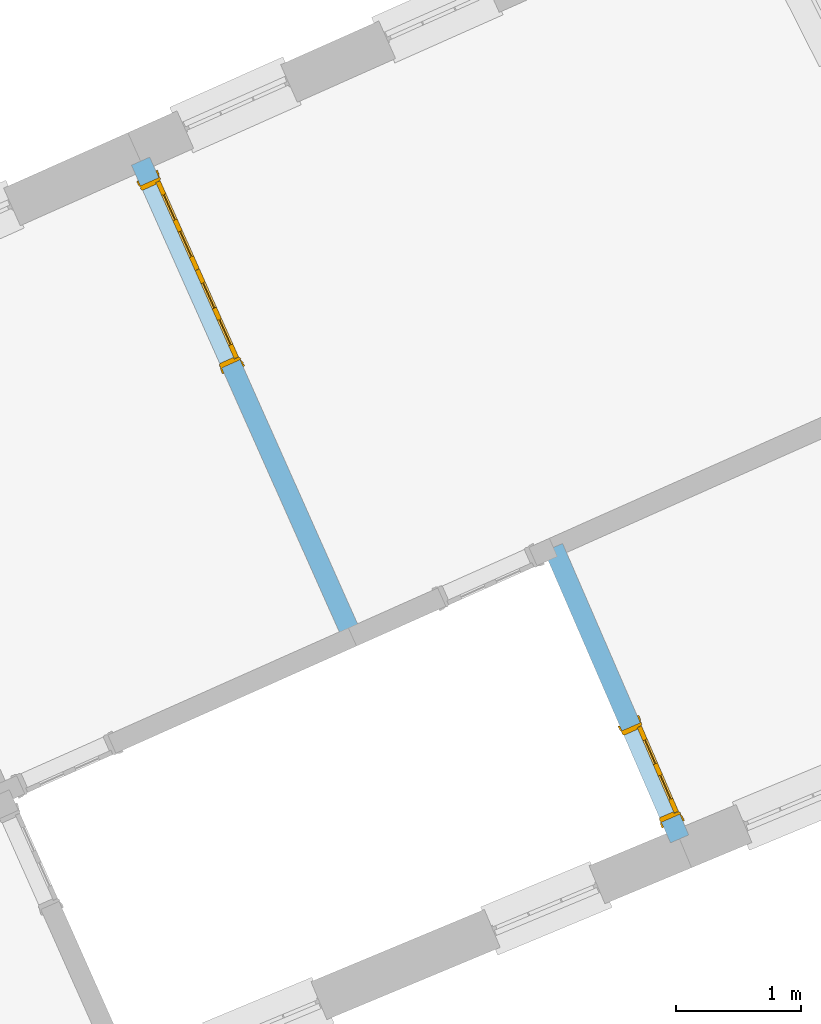
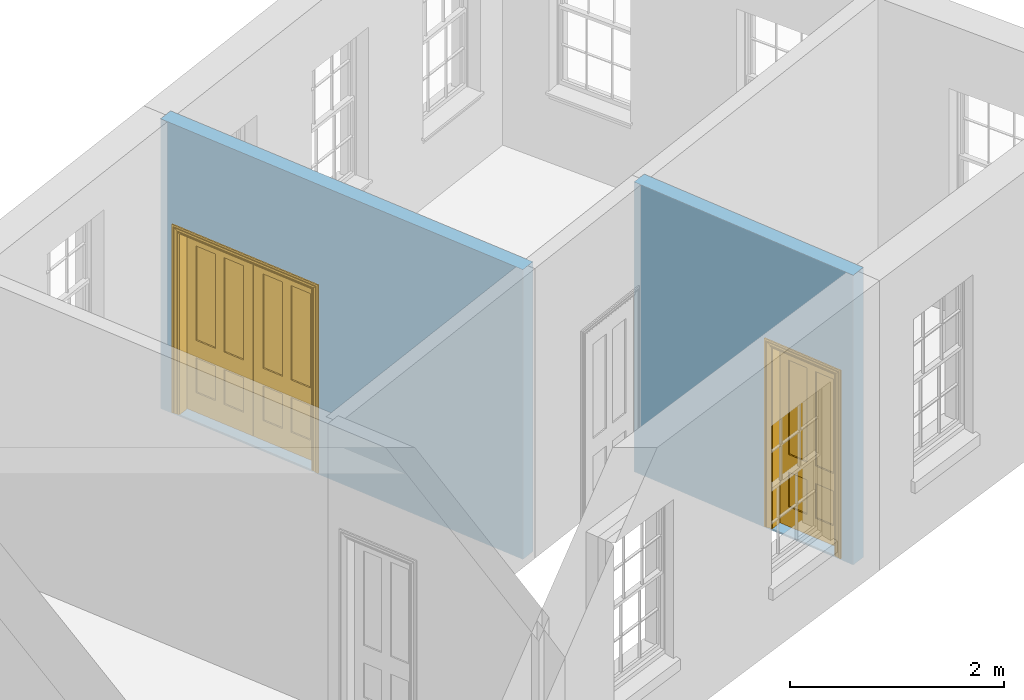
# One storey, part 5 of 8: 2 doors, 2 openings, plus 2 elements that do not belong to this part.
"""IFC2X3 building model written with IfcOpenShell, lengths in metres."""

from ifc_helpers import new_model, si_unit, frame, origin, place, context, subcontext, project, spatial, polyline, outline, extrude, faceted_brep, material, layer, layer_set, layer_usage, element, fill, save


model = new_model("IFC2X3")

# Units and contexts
model_context = context("Model", 3, world=origin())
body_context = subcontext(model_context, "Body", "Model", "MODEL_VIEW")
ifc_project = project(units=[si_unit("PLANEANGLEUNIT", "RADIAN"), si_unit("MASSUNIT", "GRAM", prefix="KILO"), si_unit("FORCEUNIT", "NEWTON", prefix="KILO"), si_unit("LENGTHUNIT", "METRE")], contexts=[model_context])

# Site, building, storey
site_placement = place(None, origin())
site = spatial("IfcSite", under=ifc_project, at=site_placement, CompositionType="ELEMENT")
building_placement = place(None, origin())
building = spatial("IfcBuilding", under=site, at=building_placement, Name="Building plot-1", CompositionType="ELEMENT")
storey_placement = place(None, frame((0.0, 0.0, 5.15)))
storey = spatial("IfcBuildingStorey", under=building, at=storey_placement, Name="Floor 1", CompositionType="ELEMENT", Elevation=5.15)

# Wall, opening, door
ifc_material = material(Name="Masonry")
ifc_layer = layer(ifc_material, 0.16, ventilated=False)
ifc_layer_set = layer_set([ifc_layer], Name="My Wall")
ifc_layer_usage = layer_usage(ifc_layer_set, "AXIS2", "NEGATIVE", 0.08)
wall_1_placement = place(storey_placement, origin())
wall_1 = element("IfcWallStandardCase", 1, at=wall_1_placement, inside=storey, material=ifc_layer_usage, Name="interior", context=body_context, shape_type="SweptSolid", body=[
    extrude(outline(polyline([(24.4842191435826, 48.6456324048901), (24.3380587544284, 48.5805390823271), (26.0373868902466, 44.7648717933949), (26.1835472794008, 44.8299651159579), (24.4842191435826, 48.6456324048901)])), origin(), (0.0, 0.0, 1.0), 3.3),
])
opening_1_placement = place(storey_placement, frame((0.0, 0.0, 0.0199999999999996)))
opening_1 = element("IfcOpeningElement", 2, at=opening_1_placement, cuts=wall_1, Name="Opening", ObjectType="Opening", context=body_context, shape_type="SweptSolid", body=[
    extrude(outline(polyline([(24.4112887423119, 48.4161086445286), (25.0622219679426, 46.9545047529869), (25.2083823570968, 47.0195980755499), (24.557449131466, 48.4812019670917), (24.4112887423119, 48.4161086445286)])), origin(), (0.0, 0.0, 1.0), 2.1),
])
door_1_placement = place(storey_placement, frame((24.484368936889, 48.4486553058102, 0.0199999999999996), z_axis=(0.0, 0.0, 1.0), x_axis=(0.650933225630723, -1.46160389154175, 0.0)))
door_1 = element("IfcDoor", 3, at=door_1_placement, inside=storey, Name="kitchen living inside door", OverallHeight=2.1, OverallWidth=1.6, context=body_context, shape_type="Brep", held_by="IfcProductRepresentation", body=[
    faceted_brep([(0.14, 0.057, 1.895), (0.14, 0.057, 0.82), (0.363, 0.057, 0.82), (0.363, 0.057, 1.895), (0.14, 0.042, 1.895), (0.14, 0.042, 0.82), (0.363, 0.042, 0.82), (0.363, 0.042, 1.895), (0.027, 0.042, 1.895), (0.027, 0.042, 0.82), (0.363, 0.042, 0.62), (0.14, 0.042, 0.62), (0.463, 0.042, 0.82), (0.463, 0.042, 1.895), (0.363, 0.042, 2.073), (0.14, 0.042, 2.073), (0.027, 0.042, 2.073), (0.027, 0.08, 1.895), (0.027, 0.08, 0.82), (0.027, 0.042, 0.62), (0.463, 0.042, 0.62), (0.14, 0.057, 0.62), (0.363, 0.057, 0.62), (0.463, 0.057, 0.82), (0.463, 0.057, 1.895), (0.463, 0.042, 2.073), (0.14, 0.08, 2.073), (0.363, 0.08, 2.073), (0.027, 0.08, 2.073), (0.14, 0.08, 1.895), (0.14, 0.08, 0.82), (0.027, 0.08, 0.62), (0.027, 0.042, 0.225), (0.14, 0.042, 0.225), (0.363, 0.042, 0.225), (0.463, 0.042, 0.225), (0.686, 0.042, 0.62), (0.686, 0.042, 0.82), (0.14, 0.057, 0.225), (0.363, 0.057, 0.225), (0.686, 0.057, 0.82), (0.686, 0.057, 1.895), (0.686, 0.042, 1.895), (0.686, 0.042, 2.073), (0.463, 0.08, 2.073), (0.363, 0.08, 1.895), (0.14, 0.065, 1.895), (0.14, 0.065, 0.82), (0.14, 0.08, 0.62), (0.027, 0.08, 0.225), (0.027, 0.042, 0.0), (0.14, 0.042, 0.0), (0.363, 0.042, 0.0), (0.463, 0.042, 0.0), (0.463, 0.057, 0.225), (0.463, 0.057, 0.62), (0.686, 0.057, 0.62), (0.799, 0.042, 0.62), (0.799, 0.042, 0.82), (0.799, 0.042, 1.895), (0.799, 0.042, 2.073), (0.686, 0.08, 2.073), (0.463, 0.08, 1.895), (0.363, 0.065, 1.895), (0.363, 0.065, 0.82), (0.363, 0.08, 0.82), (0.363, 0.08, 0.62), (0.14, 0.08, 0.225), (0.027, 0.08, 0.0), (0.14, 0.08, 0.0), (0.363, 0.08, 0.0), (0.463, 0.08, 0.0), (0.686, 0.042, 0.0), (0.686, 0.042, 0.225), (0.686, 0.057, 0.225), (0.799, 0.042, 0.225), (0.799, 0.08, 0.62), (0.799, 0.08, 0.82), (0.799, 0.08, 1.895), (0.799, 0.08, 2.073), (0.686, 0.08, 1.895), (0.463, 0.08, 0.82), (0.463, 0.08, 0.62), (0.363, 0.065, 0.62), (0.14, 0.065, 0.62), (0.14, 0.065, 0.225), (0.363, 0.08, 0.225), (0.463, 0.08, 0.225), (0.686, 0.08, 0.0), (0.799, 0.042, 0.0), (0.799, 0.08, 0.225), (0.686, 0.08, 0.62), (0.686, 0.08, 0.82), (0.686, 0.065, 1.895), (0.463, 0.065, 1.895), (0.463, 0.065, 0.82), (0.363, 0.065, 0.225), (0.686, 0.08, 0.225), (0.799, 0.08, 0.0), (0.686, 0.065, 0.82), (0.463, 0.065, 0.62), (0.463, 0.065, 0.225), (0.686, 0.065, 0.62), (0.686, 0.065, 0.225), (1.46, 0.08, 1.895), (1.237, 0.08, 1.895), (1.237, 0.08, 2.073), (1.46, 0.08, 2.073), (1.46, 0.065, 1.895), (1.237, 0.065, 1.895), (1.137, 0.08, 1.895), (1.137, 0.08, 2.073), (1.237, 0.042, 2.073), (1.46, 0.042, 2.073), (1.573, 0.08, 1.895), (1.573, 0.08, 2.073), (1.46, 0.08, 0.82), (1.46, 0.065, 0.82), (1.237, 0.065, 0.82), (1.237, 0.08, 0.82), (1.137, 0.08, 0.82), (0.914, 0.08, 2.073), (0.914, 0.08, 1.895), (1.137, 0.042, 2.073), (1.237, 0.042, 1.895), (1.46, 0.042, 1.895), (1.573, 0.042, 2.073), (1.573, 0.08, 0.82), (1.573, 0.042, 1.895), (1.237, 0.08, 0.62), (1.137, 0.08, 0.62), (1.137, 0.065, 0.82), (1.137, 0.065, 1.895), (0.914, 0.042, 2.073), (0.914, 0.065, 1.895), (0.801, 0.08, 2.073), (0.801, 0.08, 1.895), (1.137, 0.042, 1.895), (1.237, 0.057, 1.895), (1.46, 0.057, 1.895), (1.573, 0.042, 0.82), (1.573, 0.08, 0.62), (1.46, 0.08, 0.62), (1.237, 0.08, 0.225), (1.137, 0.08, 0.225), (0.914, 0.08, 0.82), (0.914, 0.08, 0.62), (0.914, 0.065, 0.82), (0.801, 0.042, 2.073), (0.914, 0.042, 1.895), (0.801, 0.08, 0.82), (0.801, 0.042, 1.895), (1.137, 0.042, 0.82), (1.237, 0.042, 0.82), (1.237, 0.057, 0.82), (1.46, 0.057, 0.82), (1.46, 0.042, 0.82), (1.573, 0.042, 0.62), (1.573, 0.08, 0.225), (1.46, 0.08, 0.225), (1.46, 0.065, 0.62), (1.237, 0.065, 0.62), (1.237, 0.08, 0.0), (1.137, 0.08, 0.0), (1.137, 0.065, 0.225), (1.137, 0.065, 0.62), (1.237, 0.065, 0.225), (0.914, 0.065, 0.62), (0.801, 0.08, 0.62), (0.914, 0.057, 1.895), (1.137, 0.057, 1.895), (0.801, 0.042, 0.82), (1.137, 0.042, 0.62), (1.237, 0.042, 0.62), (1.137, 0.057, 0.82), (1.46, 0.042, 0.62), (1.573, 0.042, 0.225), (1.573, 0.08, 0.0), (1.46, 0.08, 0.0), (1.46, 0.065, 0.225), (1.237, 0.042, 0.0), (1.137, 0.042, 0.0), (0.914, 0.08, 0.225), (0.914, 0.08, 0.0), (0.914, 0.065, 0.225), (0.801, 0.08, 0.225), (0.801, 0.042, 0.62), (0.914, 0.042, 0.82), (0.914, 0.057, 0.82), (1.137, 0.042, 0.225), (1.237, 0.042, 0.225), (0.914, 0.042, 0.62), (1.46, 0.042, 0.225), (1.573, 0.042, 0.0), (1.46, 0.042, 0.0), (0.914, 0.042, 0.0), (0.801, 0.08, 0.0), (0.801, 0.042, 0.225), (1.237, 0.057, 0.225), (1.237, 0.057, 0.62), (1.137, 0.057, 0.62), (1.137, 0.057, 0.225), (1.46, 0.057, 0.62), (0.914, 0.057, 0.62), (1.46, 0.057, 0.225), (0.914, 0.042, 0.225), (0.801, 0.042, 0.0), (0.914, 0.057, 0.225), (0.02, 0.085, 0.0), (0.005, 0.09, 0.0), (0.005, 0.09, 2.095), (0.02, 0.085, 2.08), (0.02, 0.08, 0.0), (0.0, 0.085, 0.0), (0.0, 0.085, 2.1), (1.595, 0.09, 2.095), (1.58, 0.085, 2.08), (0.02, 0.08, 2.08), (0.0, 0.08, 0.0), (-0.032, 0.095, 0.0), (-0.032, 0.095, 2.132), (1.6, 0.085, 2.1), (1.595, 0.09, 0.0), (1.58, 0.085, 0.0), (1.58, 0.08, 2.08), (0.025, 0.08, 0.0), (0.025, 0.08, 2.075), (-0.04, 0.09, 0.0), (0.025, 0.04, 0.0), (0.0, -0.08, 0.0), (-0.04, 0.09, 2.14), (1.632, 0.095, 2.132), (1.6, 0.085, 0.0), (1.58, 0.08, 0.0), (1.575, 0.08, 2.075), (0.025, 0.04, 2.075), (-0.06, 0.08, 0.0), (0.035, -0.08, 0.0), (0.0, -0.08, 2.1), (0.0, 0.08, 2.1), (-0.04, 0.095, 0.0), (-0.04, 0.095, 2.14), (1.64, 0.09, 2.14), (1.632, 0.095, 0.0), (1.6, 0.08, 0.0), (1.575, 0.08, 0.0), (1.575, 0.04, 2.075), (0.04, 0.04, 0.0), (0.04, 0.04, 2.06), (-0.06, 0.095, 0.0), (-0.06, 0.08, 2.16), (0.015, -0.085, 0.0), (0.04, -0.08, 0.0), (-0.045, -0.08, 2.145), (-0.045, -0.08, 0.0), (1.6, -0.08, 2.1), (1.6, 0.08, 2.1), (-0.06, 0.095, 2.16), (1.64, 0.095, 2.14), (1.64, 0.09, 0.0), (1.6, -0.08, 0.0), (1.575, 0.04, 0.0), (1.56, 0.04, 2.06), (0.04, -0.08, 2.06), (1.66, 0.08, 2.16), (-0.017, -0.095, 0.0), (-0.025, -0.09, 0.0), (0.02, -0.09, 0.0), (0.035, -0.085, 0.0), (0.035, -0.08, 2.065), (1.645, -0.08, 2.145), (-0.045, -0.095, 2.145), (-0.045, -0.095, 0.0), (1.66, 0.095, 2.16), (1.64, 0.095, 0.0), (1.66, 0.08, 0.0), (1.565, -0.08, 0.0), (1.56, 0.04, 0.0), (1.56, -0.08, 2.06), (-0.017, -0.095, 2.117), (-0.025, -0.09, 2.125), (0.015, -0.085, 2.085), (0.02, -0.09, 2.08), (0.035, -0.085, 2.065), (1.565, -0.08, 2.065), (1.645, -0.08, 0.0), (1.645, -0.095, 2.145), (-0.025, -0.095, 0.0), (1.66, 0.095, 0.0), (1.585, -0.085, 0.0), (1.56, -0.08, 0.0), (1.617, -0.095, 2.117), (1.625, -0.09, 2.125), (-0.025, -0.095, 2.125), (1.585, -0.085, 2.085), (1.58, -0.09, 2.08), (1.565, -0.085, 2.065), (1.625, -0.09, 0.0), (1.645, -0.095, 0.0), (1.625, -0.095, 2.125), (1.617, -0.095, 0.0), (1.565, -0.085, 0.0), (1.58, -0.09, 0.0), (1.625, -0.095, 0.0)], [[[0, 1, 2, 3]], [[1, 0, 4, 5]], [[2, 1, 5, 6]], [[6, 7, 3, 2]], [[7, 4, 0, 3]], [[4, 8, 9, 5]], [[10, 6, 5, 11]], [[6, 12, 13, 7]], [[14, 15, 4, 7]], [[15, 16, 8, 4]], [[9, 8, 17, 18]], [[5, 9, 19, 11]], [[10, 20, 12, 6]], [[10, 11, 21, 22]], [[13, 12, 23, 24]], [[7, 13, 25, 14]], [[26, 15, 14, 27]], [[28, 16, 15, 26]], [[8, 16, 28, 17]], [[17, 29, 30, 18]], [[18, 31, 19, 9]], [[11, 19, 32, 33]], [[34, 35, 20, 10]], [[20, 36, 37, 12]], [[11, 33, 38, 21]], [[39, 22, 21, 38]], [[34, 10, 22, 39]], [[12, 37, 40, 23]], [[24, 23, 40, 41]], [[42, 13, 24, 41]], [[13, 42, 43, 25]], [[14, 25, 44, 27]], [[26, 27, 45, 29]], [[28, 26, 29, 17]], [[30, 29, 46, 47]], [[18, 30, 48, 31]], [[31, 49, 32, 19]], [[33, 32, 50, 51]], [[52, 53, 35, 34]], [[20, 35, 54, 55]], [[36, 20, 55, 56]], [[36, 57, 58, 37]], [[33, 34, 39, 38]], [[37, 42, 41, 40]], [[42, 59, 60, 43]], [[44, 25, 43, 61]], [[62, 45, 27, 44]], [[29, 45, 63, 46]], [[46, 63, 64, 47]], [[65, 30, 47, 64]], [[30, 65, 66, 48]], [[31, 48, 67, 49]], [[68, 50, 32, 49]], [[68, 69, 51, 50]], [[34, 33, 51, 52]], [[53, 52, 70, 71]], [[53, 72, 73, 35]], [[35, 73, 74, 54]], [[55, 54, 74, 56]], [[73, 36, 56, 74]], [[73, 75, 57, 36]], [[57, 76, 77, 58]], [[37, 58, 59, 42]], [[78, 79, 60, 59]], [[60, 79, 61, 43]], [[80, 62, 44, 61]], [[81, 65, 45, 62]], [[45, 65, 64, 63]], [[82, 66, 65, 81]], [[48, 66, 83, 84]], [[67, 48, 84, 85]], [[49, 67, 69, 68]], [[52, 51, 69, 70]], [[71, 70, 86, 87]], [[72, 53, 71, 88]], [[72, 89, 75, 73]], [[75, 90, 76, 57]], [[76, 91, 92, 77]], [[78, 59, 58, 77]], [[78, 80, 61, 79]], [[62, 80, 93, 94]], [[81, 62, 94, 95]], [[87, 86, 66, 82]], [[91, 82, 81, 92]], [[66, 86, 96, 83]], [[84, 83, 96, 85]], [[86, 67, 85, 96]], [[67, 86, 70, 69]], [[88, 71, 87, 97]], [[89, 72, 88, 98]], [[89, 98, 90, 75]], [[90, 97, 91, 76]], [[80, 78, 77, 92]], [[80, 92, 99, 93]], [[99, 95, 94, 93]], [[92, 81, 95, 99]], [[87, 82, 100, 101]], [[82, 91, 102, 100]], [[97, 87, 101, 103]], [[98, 88, 97, 90]], [[91, 97, 103, 102]], [[103, 101, 100, 102]], [[104, 105, 106, 107]], [[105, 104, 108, 109]], [[105, 110, 111, 106]], [[106, 112, 113, 107]], [[114, 104, 107, 115]], [[104, 116, 117, 108]], [[117, 118, 109, 108]], [[119, 105, 109, 118]], [[119, 120, 110, 105]], [[121, 111, 110, 122]], [[123, 112, 106, 111]], [[124, 125, 113, 112]], [[126, 115, 107, 113]], [[104, 114, 127, 116]], [[114, 115, 126, 128]], [[116, 119, 118, 117]], [[129, 130, 120, 119]], [[110, 120, 131, 132]], [[121, 133, 123, 111]], [[122, 110, 132, 134]], [[135, 121, 122, 136]], [[137, 124, 112, 123]], [[125, 124, 138, 139]], [[125, 128, 126, 113]], [[114, 128, 140, 127]], [[141, 142, 116, 127]], [[142, 129, 119, 116]], [[143, 144, 130, 129]], [[145, 120, 130, 146]], [[120, 145, 147, 131]], [[134, 132, 131, 147]], [[135, 148, 133, 121]], [[123, 133, 149, 137]], [[145, 122, 134, 147]], [[136, 122, 145, 150]], [[151, 148, 135, 136]], [[152, 153, 124, 137]], [[124, 153, 154, 138]], [[138, 154, 155, 139]], [[156, 125, 139, 155]], [[156, 140, 128, 125]], [[157, 141, 127, 140]], [[158, 159, 142, 141]], [[129, 142, 160, 161]], [[162, 163, 144, 143]], [[130, 144, 164, 165]], [[143, 129, 161, 166]], [[146, 130, 165, 167]], [[150, 145, 146, 168]], [[133, 148, 151, 149]], [[137, 149, 169, 170]], [[171, 151, 136, 150]], [[172, 173, 153, 152]], [[152, 137, 170, 174]], [[153, 156, 155, 154]], [[175, 157, 140, 156]], [[176, 158, 141, 157]], [[177, 178, 159, 158]], [[142, 159, 179, 160]], [[179, 166, 161, 160]], [[180, 181, 163, 162]], [[182, 144, 163, 183]], [[178, 162, 143, 159]], [[144, 182, 184, 164]], [[167, 165, 164, 184]], [[159, 143, 166, 179]], [[182, 146, 167, 184]], [[168, 146, 182, 185]], [[150, 168, 186, 171]], [[149, 151, 171, 187]], [[149, 187, 188, 169]], [[169, 188, 174, 170]], [[189, 190, 173, 172]], [[173, 175, 156, 153]], [[172, 152, 187, 191]], [[187, 152, 174, 188]], [[192, 176, 157, 175]], [[193, 177, 158, 176]], [[193, 194, 178, 177]], [[181, 180, 190, 189]], [[181, 195, 183, 163]], [[194, 180, 162, 178]], [[185, 182, 183, 196]], [[168, 185, 197, 186]], [[187, 171, 186, 191]], [[173, 190, 198, 199]], [[189, 172, 200, 201]], [[175, 173, 199, 202]], [[172, 191, 203, 200]], [[194, 193, 176, 192]], [[192, 175, 202, 204]], [[180, 194, 192, 190]], [[189, 205, 195, 181]], [[196, 183, 195, 206]], [[196, 206, 197, 185]], [[191, 186, 197, 205]], [[190, 192, 204, 198]], [[199, 198, 204, 202]], [[201, 200, 203, 207]], [[205, 189, 201, 207]], [[191, 205, 207, 203]], [[205, 197, 206, 195]], [[208, 209, 210, 211]], [[208, 212, 213, 209]], [[209, 213, 214, 210]], [[211, 210, 215, 216]], [[211, 217, 212, 208]], [[218, 213, 212]], [[213, 219, 220, 214]], [[210, 214, 221, 215]], [[216, 215, 222, 223]], [[217, 211, 216, 224]], [[225, 212, 217, 226]], [[219, 213, 218, 227]], [[218, 212, 228, 229]], [[219, 227, 230, 220]], [[214, 220, 231, 221]], [[215, 221, 232, 222]], [[222, 232, 233, 223]], [[224, 216, 223, 233]], [[226, 217, 224, 234]], [[225, 228, 212]], [[235, 228, 225, 226]], [[236, 227, 218]], [[237, 229, 228]], [[229, 238, 239, 218]], [[227, 240, 241, 230]], [[220, 230, 242, 231]], [[221, 231, 243, 232]], [[244, 233, 232]], [[234, 224, 233, 245]], [[246, 235, 226, 234]], [[247, 228, 235, 248]], [[240, 227, 236, 249]], [[239, 250, 236, 218]], [[251, 229, 237]], [[252, 237, 228, 247]], [[253, 238, 229, 254]], [[238, 255, 256, 239]], [[241, 240, 257]], [[230, 241, 258, 242]], [[231, 242, 259, 243]], [[259, 244, 232, 243]], [[260, 261, 233, 244]], [[245, 233, 261]], [[261, 246, 234, 245]], [[248, 235, 246, 262]], [[248, 263, 252, 247]], [[250, 257, 249, 236]], [[240, 249, 257]], [[256, 264, 250, 239]], [[265, 266, 229, 251]], [[267, 251, 237, 268]], [[263, 269, 237, 252]], [[270, 255, 238, 253]], [[229, 266, 254]], [[271, 253, 254, 272]], [[256, 255, 260, 244]], [[273, 241, 257]], [[273, 258, 241]], [[242, 258, 274, 259]], [[275, 244, 259]], [[260, 276, 261]], [[261, 277, 262, 246]], [[262, 278, 263, 248]], [[264, 273, 257, 250]], [[244, 275, 264, 256]], [[266, 265, 279, 280]], [[265, 251, 281, 279]], [[251, 267, 282, 281]], [[269, 283, 268, 237]], [[267, 268, 283, 282]], [[278, 284, 269, 263]], [[285, 260, 255, 270]], [[286, 270, 253, 271]], [[272, 254, 266, 287]], [[271, 272, 287]], [[273, 274, 258]], [[288, 275, 259, 274]], [[276, 260, 289]], [[277, 261, 276, 290]], [[278, 262, 277, 290]], [[275, 288, 273, 264]], [[280, 279, 291, 292]], [[287, 266, 280, 293]], [[279, 281, 294, 291]], [[281, 282, 295, 294]], [[284, 296, 283, 269]], [[282, 283, 296, 295]], [[290, 276, 284, 278]], [[285, 297, 260]], [[298, 285, 270, 286]], [[299, 286, 271]], [[271, 287, 293]], [[273, 288, 274]], [[300, 289, 260, 297]], [[301, 276, 289, 302]], [[292, 291, 300, 297]], [[293, 280, 292, 299]], [[291, 294, 289, 300]], [[294, 295, 302, 289]], [[296, 284, 276, 301]], [[295, 296, 301, 302]], [[303, 297, 285, 298]], [[299, 298, 286]], [[271, 293, 299]], [[299, 292, 297, 303]], [[299, 303, 298]]]),
])
fill(opening_1, door_1)

wall_2_placement = place(storey_placement, origin())
wall_2 = element("IfcWallStandardCase", 4, at=wall_2_placement, inside=storey, material=ifc_layer_usage, Name="interior", context=body_context, shape_type="SweptSolid", body=[
    extrude(outline(polyline([(27.7956430256276, 45.5470126988155), (27.6488155837474, 45.4834383147375), (28.6608926021956, 43.146008204173), (28.8077200440758, 43.209582588251), (27.7956430256276, 45.5470126988155)])), origin(), (0.0, 0.0, 1.0), 3.3),
])
opening_2_placement = place(storey_placement, frame((0.0, 0.0, 0.0199999999999996)))
opening_2 = element("IfcOpeningElement", 5, at=opening_2_placement, cuts=wall_2, Name="Opening", ObjectType="Opening", context=body_context, shape_type="SweptSolid", body=[
    extrude(outline(polyline([(28.2714994997177, 44.0453262856896), (28.5893714201078, 43.3111890762883), (28.7361988619881, 43.3747634603663), (28.418326941598, 44.1089006697676), (28.2714994997177, 44.0453262856896)])), origin(), (0.0, 0.0, 1.0), 2.1),
])
door_2_placement = place(storey_placement, frame((28.3449132206578, 44.0771134777286, 0.0199999999999996), z_axis=(0.0, 0.0, 1.0), x_axis=(0.317871920390086, -0.734137209401297, 0.0)))
door_2 = element("IfcDoor", 6, at=door_2_placement, inside=storey, Name="toilet inside door", OverallHeight=2.1, OverallWidth=0.8, context=body_context, shape_type="Brep", held_by="IfcProductRepresentation", body=[
    faceted_brep([(0.773, 0.08, 1.895), (0.66, 0.08, 1.895), (0.66, 0.08, 2.073), (0.773, 0.08, 2.073), (0.773, 0.08, 0.82), (0.66, 0.08, 0.82), (0.45, 0.08, 1.895), (0.45, 0.08, 2.073), (0.773, 0.08, 0.62), (0.66, 0.08, 0.62), (0.66, 0.065, 0.82), (0.66, 0.065, 1.895), (0.45, 0.065, 1.895), (0.35, 0.08, 1.895), (0.35, 0.08, 2.073), (0.773, 0.08, 0.225), (0.66, 0.08, 0.225), (0.45, 0.08, 0.62), (0.45, 0.08, 0.82), (0.45, 0.065, 0.82), (0.35, 0.08, 0.82), (0.14, 0.08, 2.073), (0.14, 0.08, 1.895), (0.773, 0.08, 0.0), (0.66, 0.08, 0.0), (0.66, 0.065, 0.225), (0.66, 0.065, 0.62), (0.45, 0.065, 0.62), (0.35, 0.08, 0.62), (0.35, 0.065, 0.82), (0.35, 0.065, 1.895), (0.14, 0.065, 1.895), (0.027, 0.08, 2.073), (0.027, 0.08, 1.895), (0.773, 0.042, 0.0), (0.66, 0.042, 0.0), (0.45, 0.08, 0.0), (0.45, 0.08, 0.225), (0.45, 0.065, 0.225), (0.35, 0.08, 0.225), (0.14, 0.08, 0.82), (0.14, 0.08, 0.62), (0.14, 0.065, 0.82), (0.027, 0.08, 0.82), (0.773, 0.042, 0.225), (0.66, 0.042, 0.225), (0.45, 0.042, 0.0), (0.35, 0.08, 0.0), (0.35, 0.065, 0.225), (0.35, 0.065, 0.62), (0.14, 0.065, 0.62), (0.027, 0.08, 0.62), (0.773, 0.042, 0.62), (0.66, 0.042, 0.62), (0.45, 0.042, 0.225), (0.35, 0.042, 0.0), (0.14, 0.08, 0.225), (0.14, 0.08, 0.0), (0.14, 0.065, 0.225), (0.027, 0.08, 0.225), (0.773, 0.042, 0.82), (0.66, 0.042, 0.82), (0.66, 0.057, 0.62), (0.66, 0.057, 0.225), (0.45, 0.057, 0.225), (0.35, 0.042, 0.225), (0.14, 0.042, 0.0), (0.027, 0.08, 0.0), (0.773, 0.042, 1.895), (0.66, 0.042, 1.895), (0.45, 0.042, 0.62), (0.45, 0.042, 0.82), (0.45, 0.057, 0.62), (0.35, 0.042, 0.62), (0.14, 0.042, 0.225), (0.027, 0.042, 0.0), (0.773, 0.042, 2.073), (0.66, 0.042, 2.073), (0.66, 0.057, 1.895), (0.66, 0.057, 0.82), (0.45, 0.057, 0.82), (0.35, 0.042, 0.82), (0.35, 0.057, 0.62), (0.35, 0.057, 0.225), (0.14, 0.057, 0.225), (0.027, 0.042, 0.225), (0.45, 0.042, 1.895), (0.45, 0.042, 2.073), (0.45, 0.057, 1.895), (0.35, 0.042, 1.895), (0.14, 0.042, 0.82), (0.14, 0.042, 0.62), (0.14, 0.057, 0.62), (0.027, 0.042, 0.62), (0.35, 0.042, 2.073), (0.35, 0.057, 1.895), (0.35, 0.057, 0.82), (0.14, 0.057, 0.82), (0.027, 0.042, 0.82), (0.14, 0.042, 2.073), (0.14, 0.042, 1.895), (0.14, 0.057, 1.895), (0.027, 0.042, 1.895), (0.027, 0.042, 2.073), (0.02, 0.085, 0.0), (0.005, 0.09, 0.0), (0.005, 0.09, 2.095), (0.02, 0.085, 2.08), (0.02, 0.08, 0.0), (0.0, 0.085, 0.0), (0.0, 0.085, 2.1), (0.795, 0.09, 2.095), (0.78, 0.085, 2.08), (0.02, 0.08, 2.08), (0.0, 0.08, 0.0), (-0.032, 0.095, 0.0), (-0.032, 0.095, 2.132), (0.8, 0.085, 2.1), (0.795, 0.09, 0.0), (0.78, 0.085, 0.0), (0.78, 0.08, 2.08), (0.04, 0.04, 0.0), (0.025, 0.04, 0.0), (0.025, 0.04, 2.075), (0.04, 0.04, 2.06), (-0.04, 0.09, 0.0), (-0.04, 0.09, 2.14), (0.832, 0.095, 2.132), (0.8, 0.085, 0.0), (0.78, 0.08, 0.0), (0.8, 0.08, 0.0), (0.86, 0.08, 0.0), (0.86, 0.08, 2.16), (0.8, 0.08, 2.1), (-0.06, 0.08, 2.16), (0.0, 0.08, 2.1), (-0.06, 0.08, 0.0), (-0.04, 0.095, 0.0), (-0.04, 0.095, 2.14), (0.84, 0.09, 2.14), (0.832, 0.095, 0.0), (0.84, 0.09, 0.0), (0.86, 0.095, 0.0), (0.86, 0.095, 2.16), (-0.06, 0.095, 2.16), (-0.06, 0.095, 0.0), (0.84, 0.095, 0.0), (0.84, 0.095, 2.14), (-0.025, -0.095, 0.0), (-0.025, -0.09, 0.0), (-0.025, -0.09, 2.125), (-0.025, -0.095, 2.125), (-0.017, -0.095, 0.0), (-0.017, -0.095, 2.117), (0.825, -0.09, 2.125), (0.825, -0.095, 2.125), (0.825, -0.095, 0.0), (0.845, -0.095, 0.0), (-0.045, -0.095, 2.145), (-0.045, -0.095, 0.0), (0.845, -0.095, 2.145), (0.015, -0.085, 0.0), (0.015, -0.085, 2.085), (0.817, -0.095, 2.117), (0.825, -0.09, 0.0), (0.845, -0.08, 0.0), (0.845, -0.08, 2.145), (-0.045, -0.08, 2.145), (-0.045, -0.08, 0.0), (0.02, -0.09, 0.0), (0.02, -0.09, 2.08), (0.785, -0.085, 2.085), (0.817, -0.095, 0.0), (0.8, -0.08, 0.0), (0.8, -0.08, 2.1), (0.0, -0.08, 2.1), (0.0, -0.08, 0.0), (0.035, -0.085, 0.0), (0.035, -0.085, 2.065), (0.78, -0.09, 2.08), (0.785, -0.085, 0.0), (0.775, 0.04, 2.075), (0.76, 0.04, 2.06), (0.035, -0.08, 2.065), (0.035, -0.08, 0.0), (0.765, -0.085, 2.065), (0.78, -0.09, 0.0), (0.765, -0.08, 0.0), (0.765, -0.08, 2.065), (0.765, -0.085, 0.0), (0.04, -0.08, 2.06), (0.04, -0.08, 0.0), (0.76, -0.08, 2.06), (0.76, -0.08, 0.0), (0.76, 0.04, 0.0), (0.775, 0.04, 0.0), (0.025, 0.08, 0.0), (0.025, 0.08, 2.075), (0.775, 0.08, 0.0), (0.775, 0.08, 2.075)], [[[0, 1, 2, 3]], [[1, 0, 4, 5]], [[1, 6, 7, 2]], [[8, 9, 5, 4]], [[1, 5, 10, 11]], [[6, 1, 11, 12]], [[6, 13, 14, 7]], [[15, 16, 9, 8]], [[9, 17, 18, 5]], [[5, 18, 19, 10]], [[10, 19, 12, 11]], [[18, 6, 12, 19]], [[18, 20, 13, 6]], [[21, 14, 13, 22]], [[23, 24, 16, 15]], [[9, 16, 25, 26]], [[17, 9, 26, 27]], [[17, 28, 20, 18]], [[13, 20, 29, 30]], [[22, 13, 30, 31]], [[32, 21, 22, 33]], [[34, 35, 24, 23]], [[24, 36, 37, 16]], [[16, 37, 38, 25]], [[25, 38, 27, 26]], [[37, 17, 27, 38]], [[37, 39, 28, 17]], [[40, 20, 28, 41]], [[20, 40, 42, 29]], [[31, 30, 29, 42]], [[40, 22, 31, 42]], [[33, 22, 40, 43]], [[35, 34, 44, 45]], [[35, 46, 36, 24]], [[36, 47, 39, 37]], [[28, 39, 48, 49]], [[41, 28, 49, 50]], [[43, 40, 41, 51]], [[45, 44, 52, 53]], [[46, 35, 45, 54]], [[46, 55, 47, 36]], [[56, 39, 47, 57]], [[39, 56, 58, 48]], [[50, 49, 48, 58]], [[56, 41, 50, 58]], [[51, 41, 56, 59]], [[53, 52, 60, 61]], [[45, 53, 62, 63]], [[54, 45, 63, 64]], [[55, 46, 54, 65]], [[55, 66, 57, 47]], [[59, 56, 57, 67]], [[61, 60, 68, 69]], [[70, 53, 61, 71]], [[53, 70, 72, 62]], [[72, 64, 63, 62]], [[70, 54, 64, 72]], [[65, 54, 70, 73]], [[65, 74, 66, 55]], [[67, 57, 66, 75]], [[69, 68, 76, 77]], [[61, 69, 78, 79]], [[71, 61, 79, 80]], [[73, 70, 71, 81]], [[65, 73, 82, 83]], [[74, 65, 83, 84]], [[74, 85, 75, 66]], [[86, 69, 77, 87]], [[69, 86, 88, 78]], [[88, 80, 79, 78]], [[86, 71, 80, 88]], [[81, 71, 86, 89]], [[73, 81, 90, 91]], [[73, 91, 92, 82]], [[83, 82, 92, 84]], [[91, 74, 84, 92]], [[91, 93, 85, 74]], [[89, 86, 87, 94]], [[81, 89, 95, 96]], [[90, 81, 96, 97]], [[90, 98, 93, 91]], [[94, 99, 100, 89]], [[89, 100, 101, 95]], [[101, 97, 96, 95]], [[100, 90, 97, 101]], [[100, 102, 98, 90]], [[99, 103, 102, 100]], [[32, 103, 99, 21]], [[102, 103, 32, 33]], [[98, 102, 33, 43]], [[21, 99, 94, 14]], [[94, 87, 7, 14]], [[7, 87, 77, 2]], [[76, 3, 2, 77]], [[43, 51, 93, 98]], [[51, 59, 85, 93]], [[67, 75, 85, 59]], [[34, 23, 15, 44]], [[44, 15, 8, 52]], [[52, 8, 4, 60]], [[0, 68, 60, 4]], [[0, 3, 76, 68]], [[104, 105, 106, 107]], [[104, 108, 109, 105]], [[105, 109, 110, 106]], [[107, 106, 111, 112]], [[107, 113, 108, 104]], [[114, 109, 108]], [[109, 115, 116, 110]], [[106, 110, 117, 111]], [[112, 111, 118, 119]], [[113, 107, 112, 120]], [[121, 122, 123, 124]], [[115, 109, 114, 125]], [[115, 125, 126, 116]], [[110, 116, 127, 117]], [[111, 117, 128, 118]], [[118, 128, 129, 119]], [[120, 112, 119, 129]], [[130, 129, 128]], [[130, 131, 132, 133]], [[133, 132, 134, 135]], [[135, 134, 136, 114]], [[136, 125, 114]], [[125, 137, 138, 126]], [[116, 126, 139, 127]], [[117, 127, 140, 128]], [[141, 130, 128, 140]], [[131, 130, 141]], [[131, 142, 143, 132]], [[132, 143, 144, 134]], [[134, 144, 145, 136]], [[137, 125, 136, 145]], [[143, 142, 146]], [[143, 146, 147]], [[137, 145, 144]], [[143, 147, 138]], [[138, 137, 144]], [[143, 138, 144]], [[126, 138, 147, 139]], [[127, 139, 141, 140]], [[142, 131, 141, 146]], [[139, 147, 146, 141]], [[148, 149, 150, 151]], [[149, 152, 153, 150]], [[151, 150, 154, 155]], [[155, 156, 157]], [[158, 159, 148]], [[158, 148, 151]], [[155, 157, 160]], [[158, 151, 155]], [[155, 160, 158]], [[152, 161, 162, 153]], [[150, 153, 163, 154]], [[155, 154, 164, 156]], [[156, 164, 165, 157]], [[157, 165, 166, 160]], [[160, 166, 167, 158]], [[158, 167, 168, 159]], [[161, 169, 170, 162]], [[153, 162, 171, 163]], [[154, 163, 172, 164]], [[165, 164, 173]], [[165, 173, 174, 166]], [[166, 174, 175, 167]], [[167, 175, 176, 168]], [[169, 177, 178, 170]], [[162, 170, 179, 171]], [[163, 171, 180, 172]], [[172, 180, 173, 164]], [[124, 123, 181, 182]], [[183, 178, 177, 184]], [[170, 178, 185, 179]], [[171, 179, 186, 180]], [[187, 173, 180]], [[185, 188, 187, 189]], [[188, 185, 178, 183]], [[179, 185, 189, 186]], [[189, 187, 180, 186]], [[190, 183, 184, 191]], [[192, 188, 183, 190]], [[191, 184, 122, 121]], [[124, 190, 191, 121]], [[193, 187, 188, 192]], [[182, 192, 190, 124]], [[184, 176, 122]], [[194, 195, 187, 193]], [[192, 182, 194, 193]], [[161, 176, 184]], [[114, 108, 122, 176]], [[173, 187, 195]], [[152, 149, 176, 161]], [[169, 161, 184, 177]], [[196, 122, 108]], [[176, 175, 135, 114]], [[173, 195, 129, 130]], [[176, 149, 168]], [[123, 122, 196, 197]], [[196, 108, 113, 197]], [[175, 174, 133, 135]], [[198, 129, 195]], [[133, 174, 173, 130]], [[159, 168, 149, 148]], [[181, 123, 197, 199]], [[197, 113, 120, 199]], [[199, 120, 129, 198]], [[195, 181, 199, 198]], [[195, 194, 182, 181]]]),
])
fill(opening_2, door_2)

save(model, "model.ifc")
